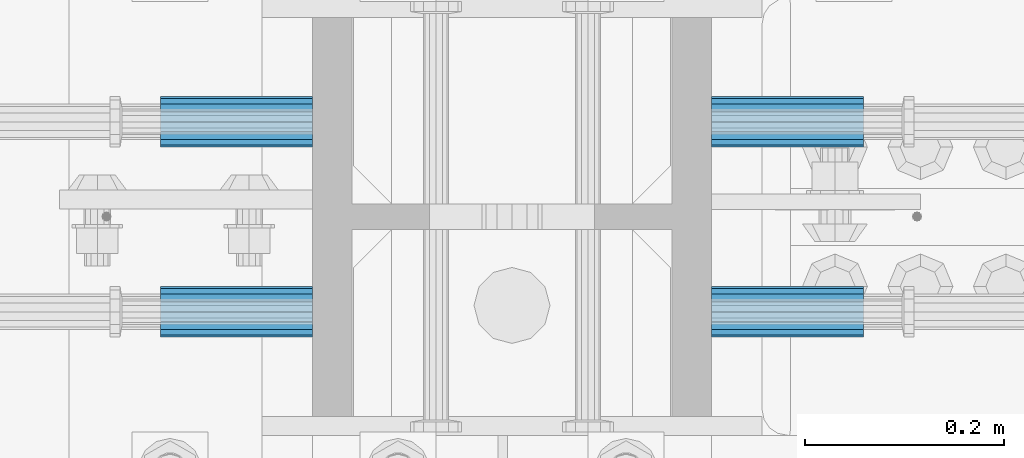
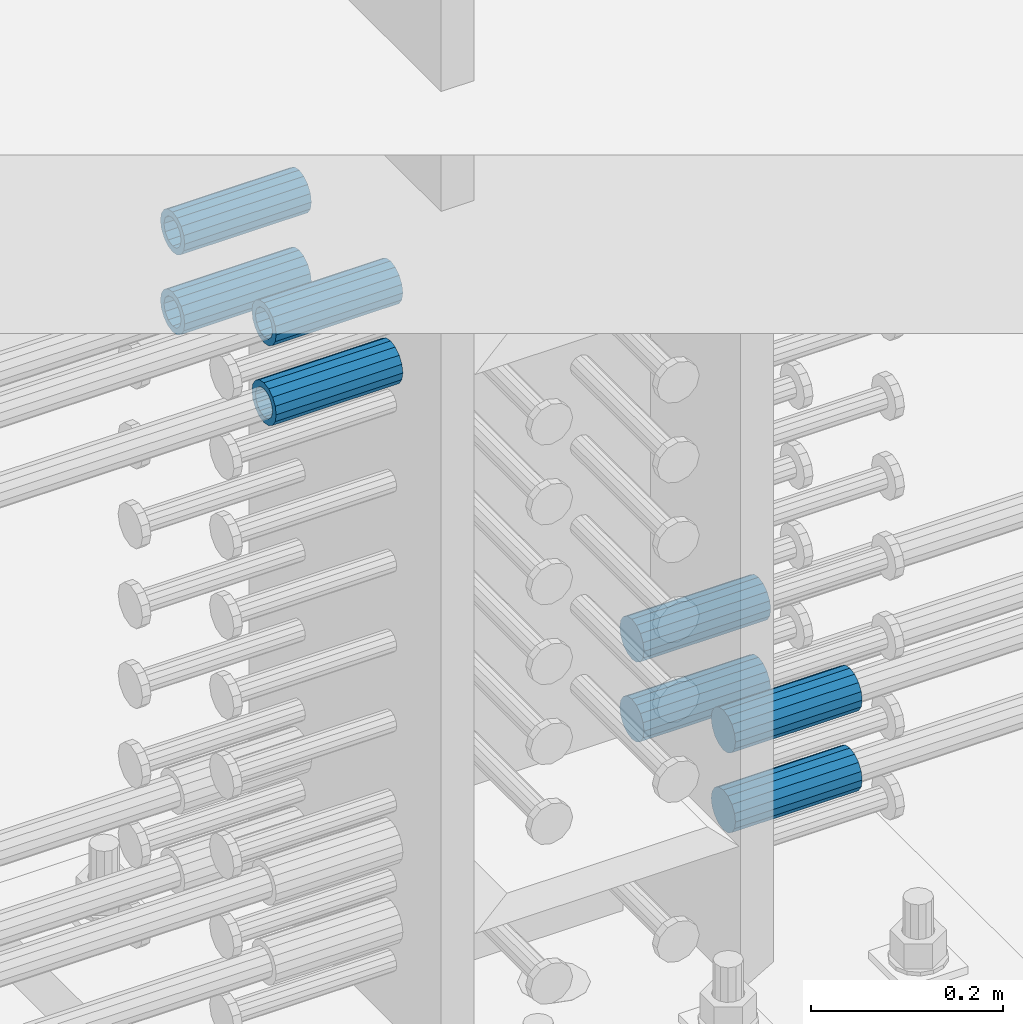
# One storey, part 1187 of 1763: 8 beams, 1 element without a shape of its own.
"""IFC2X3 building model written with IfcOpenShell, lengths in millimetres."""

from ifc_helpers import new_model, si_unit, frame, origin_with_axes, place, context, subcontext, project, spatial, faceted_brep, material, type_object, element, aggregate, save


model = new_model("IFC2X3")

# Units and contexts
model_context = context("Model", 3, precision=1e-05, world=origin_with_axes())
body_context = subcontext(model_context, "Body", "Model", "MODEL_VIEW")
ifc_project = project(units=[si_unit("LENGTHUNIT", "METRE", prefix="MILLI"), si_unit("AREAUNIT", "SQUARE_METRE"), si_unit("VOLUMEUNIT", "CUBIC_METRE"), si_unit("MASSUNIT", "GRAM", prefix="KILO"), si_unit("TIMEUNIT", "SECOND"), si_unit("PLANEANGLEUNIT", "RADIAN"), si_unit("SOLIDANGLEUNIT", "STERADIAN"), si_unit("THERMODYNAMICTEMPERATUREUNIT", "DEGREE_CELSIUS"), si_unit("LUMINOUSINTENSITYUNIT", "LUMEN")], contexts=[model_context])

# Site, building, storey
site_placement = place(None, origin_with_axes())
site = spatial("IfcSite", under=ifc_project, at=site_placement, CompositionType="ELEMENT")
building_placement = place(site_placement, origin_with_axes())
building = spatial("IfcBuilding", under=site, at=building_placement, Name="Undefined", CompositionType="ELEMENT")
storey_placement = place(building_placement, origin_with_axes())
storey = spatial("IfcBuildingStorey", under=building, at=storey_placement, Name="Undefined", CompositionType="ELEMENT", Elevation=0.0)

# Assembly, beams
assembly_placement = place(storey_placement, origin_with_axes())
assembly = element("IfcElementAssembly", 1, at=assembly_placement, inside=storey, Name="COLUMN", AssemblyPlace="NOTDEFINED", PredefinedType="RIGID_FRAME")
ifc_material = material(Name="STEEL/A706-GR.80")
beam_type = type_object("IfcBeamType", PredefinedType="NOTDEFINED")
beam_1_placement = place(assembly_placement, frame((-72691.062342359, 552.450000000255, 4775.20000000008), z_axis=(0.0, 0.0, 1.0), x_axis=(-1.0, 0.0, 0.0)))
beam_1 = element("IfcBeam", 2, at=beam_1_placement, type_object=beam_type, material=ifc_material, Name="HALF COUPLER F", context=body_context, shape_type="Brep", body=[
    faceted_brep([(32.7659999999996, -8.95349999999962, -15.507916905568), (32.7659999999996, 0.0, -17.9070000000002), (32.7659999999996, 8.95349999999962, -15.507916905568), (32.7659999999996, 15.507916905568, -8.95350000000008), (32.7659999999996, 17.9069999999992, 0.0), (32.7659999999996, 15.507916905568, 8.95350000000008), (32.7659999999996, 8.95349999999962, 15.507916905568), (32.7659999999996, 0.0, 17.9070000000002), (32.7659999999996, -8.95349999999962, 15.507916905568), (32.7659999999996, -15.507916905568, 8.95350000000008), (32.7659999999996, -17.9069999999992, 0.0), (32.7659999999996, -15.507916905568, -8.95350000000008), (152.400103102711, -15.507916905568, 8.95350000000008), (152.400103102711, -8.95349999999962, 15.507916905568), (152.400103102711, -17.9069999999992, 0.0), (152.400103102711, -15.507916905568, -8.95350000000008), (152.400103102711, -8.95349999999962, -15.507916905568), (152.400103102711, 0.0, -17.9070000000002), (152.400103102711, 8.95349999999962, -15.507916905568), (152.400103102711, 15.507916905568, -8.95350000000008), (152.400103102711, 17.9069999999992, 0.0), (152.400103102711, 15.507916905568, 8.95350000000008), (152.400103102711, 8.95349999999962, 15.507916905568), (152.400103102711, 0.0, 17.9070000000002), (0.0, -23.466540125788, 9.72015918207308), (0.0, -17.9605122421381, 17.9605122421385), (0.0, -9.72015918207398, 23.4665401257867), (0.0, 0.0, 25.4000000000001), (0.0, 9.72015918207398, 23.4665401257867), (0.0, 17.9605122421381, 17.9605122421385), (0.0, 23.466540125788, 9.72015918207308), (0.0, 25.4000000000015, 0.0), (0.0, 23.466540125788, -9.72015918207308), (0.0, 17.9605122421381, -17.9605122421385), (0.0, 9.72015918207398, -23.4665401257867), (0.0, 0.0, -25.4000000000001), (0.0, -9.72015918207398, -23.4665401257867), (0.0, -17.9605122421381, -17.9605122421385), (0.0, -23.466540125788, -9.72015918207308), (0.0, -25.4000000000015, 0.0), (152.400103102711, -25.4000000000015, 0.0), (152.400103102711, -23.466540125788, 9.72015918207308), (152.400103102711, -17.9605122421381, 17.9605122421385), (152.400103102711, -9.72015918207398, 23.4665401257867), (152.400103102711, 0.0, 25.4000000000001), (152.400103102711, 9.72015918207398, 23.4665401257867), (152.400103102711, 17.9605122421381, 17.9605122421385), (152.400103102711, 23.466540125788, 9.72015918207308), (152.400103102711, 25.4000000000015, 0.0), (152.400103102711, 23.466540125788, -9.72015918207308), (152.400103102711, 17.9605122421381, -17.9605122421385), (152.400103102711, 9.72015918207398, -23.4665401257867), (152.400103102711, 0.0, -25.4000000000001), (152.400103102711, -9.72015918207398, -23.4665401257867), (152.400103102711, -17.9605122421381, -17.9605122421385), (152.400103102711, -23.466540125788, -9.72015918207308)], [[[0, 1, 2, 3, 4, 5, 6, 7, 8, 9, 10, 11]], [[12, 9, 8, 13]], [[14, 10, 9, 12]], [[15, 11, 10, 14]], [[16, 0, 11, 15]], [[17, 1, 0, 16]], [[18, 2, 1, 17]], [[19, 3, 2, 18]], [[20, 4, 3, 19]], [[21, 5, 4, 20]], [[22, 6, 5, 21]], [[23, 7, 6, 22]], [[13, 8, 7, 23]], [[24, 25, 26, 27, 28, 29, 30, 31, 32, 33, 34, 35, 36, 37, 38, 39]], [[24, 39, 40, 41]], [[25, 24, 41, 42]], [[26, 25, 42, 43]], [[27, 26, 43, 44]], [[28, 27, 44, 45]], [[29, 28, 45, 46]], [[30, 29, 46, 47]], [[31, 30, 47, 48]], [[32, 31, 48, 49]], [[33, 32, 49, 50]], [[34, 33, 50, 51]], [[35, 34, 51, 52]], [[36, 35, 52, 53]], [[37, 36, 53, 54]], [[38, 37, 54, 55]], [[39, 38, 55, 40]], [[54, 53, 52, 51, 50, 49, 48, 47, 46, 45, 44, 43, 42, 41, 40, 55], [21, 20, 19, 18, 17, 16, 15, 14, 12, 13, 23, 22]]]),
])
beam_2_placement = place(assembly_placement, frame((-72691.0622736972, 361.950000000843, 4775.20000000008), z_axis=(0.0, 0.0, 1.0), x_axis=(-1.0, 0.0, 0.0)))
beam_2 = element("IfcBeam", 3, at=beam_2_placement, type_object=beam_type, material=ifc_material, Name="HALF COUPLER F", context=body_context, shape_type="Brep", body=[
    faceted_brep([(32.7659999999996, -8.95349999999962, -15.507916905568), (32.7659999999996, 0.0, -17.9070000000002), (32.7659999999996, 8.95349999999962, -15.507916905568), (32.7659999999996, 15.507916905568, -8.95350000000008), (32.7659999999996, 17.9069999999992, 0.0), (32.7659999999996, 15.507916905568, 8.95350000000008), (32.7659999999996, 8.95349999999962, 15.507916905568), (32.7659999999996, 0.0, 17.9070000000002), (32.7659999999996, -8.95349999999962, 15.507916905568), (32.7659999999996, -15.507916905568, 8.95350000000008), (32.7659999999996, -17.9069999999992, 0.0), (32.7659999999996, -15.507916905568, -8.95350000000008), (152.400103102711, -15.507916905568, 8.95350000000008), (152.400103102711, -8.95349999999962, 15.507916905568), (152.400103102711, -17.9069999999992, 0.0), (152.400103102711, -15.507916905568, -8.95350000000008), (152.400103102711, -8.95349999999962, -15.507916905568), (152.400103102711, 0.0, -17.9070000000002), (152.400103102711, 8.95349999999962, -15.507916905568), (152.400103102711, 15.507916905568, -8.95350000000008), (152.400103102711, 17.9069999999992, 0.0), (152.400103102711, 15.507916905568, 8.95350000000008), (152.400103102711, 8.95349999999962, 15.507916905568), (152.400103102711, 0.0, 17.9070000000002), (0.0, -23.466540125788, 9.72015918207308), (0.0, -17.9605122421381, 17.9605122421385), (0.0, -9.72015918207398, 23.4665401257867), (0.0, 0.0, 25.4000000000001), (0.0, 9.72015918207398, 23.4665401257867), (0.0, 17.9605122421381, 17.9605122421385), (0.0, 23.466540125788, 9.72015918207308), (0.0, 25.4000000000015, 0.0), (0.0, 23.466540125788, -9.72015918207308), (0.0, 17.9605122421381, -17.9605122421385), (0.0, 9.72015918207398, -23.4665401257867), (0.0, 0.0, -25.4000000000001), (0.0, -9.72015918207398, -23.4665401257867), (0.0, -17.9605122421381, -17.9605122421385), (0.0, -23.466540125788, -9.72015918207308), (0.0, -25.4000000000015, 0.0), (152.400103102711, -25.4000000000015, 0.0), (152.400103102711, -23.466540125788, 9.72015918207308), (152.400103102711, -17.9605122421381, 17.9605122421385), (152.400103102711, -9.72015918207398, 23.4665401257867), (152.400103102711, 0.0, 25.4000000000001), (152.400103102711, 9.72015918207398, 23.4665401257867), (152.400103102711, 17.9605122421381, 17.9605122421385), (152.400103102711, 23.466540125788, 9.72015918207308), (152.400103102711, 25.4000000000015, 0.0), (152.400103102711, 23.466540125788, -9.72015918207308), (152.400103102711, 17.9605122421381, -17.9605122421385), (152.400103102711, 9.72015918207398, -23.4665401257867), (152.400103102711, 0.0, -25.4000000000001), (152.400103102711, -9.72015918207398, -23.4665401257867), (152.400103102711, -17.9605122421381, -17.9605122421385), (152.400103102711, -23.466540125788, -9.72015918207308)], [[[0, 1, 2, 3, 4, 5, 6, 7, 8, 9, 10, 11]], [[12, 9, 8, 13]], [[14, 10, 9, 12]], [[15, 11, 10, 14]], [[16, 0, 11, 15]], [[17, 1, 0, 16]], [[18, 2, 1, 17]], [[19, 3, 2, 18]], [[20, 4, 3, 19]], [[21, 5, 4, 20]], [[22, 6, 5, 21]], [[23, 7, 6, 22]], [[13, 8, 7, 23]], [[24, 25, 26, 27, 28, 29, 30, 31, 32, 33, 34, 35, 36, 37, 38, 39]], [[24, 39, 40, 41]], [[25, 24, 41, 42]], [[26, 25, 42, 43]], [[27, 26, 43, 44]], [[28, 27, 44, 45]], [[29, 28, 45, 46]], [[30, 29, 46, 47]], [[31, 30, 47, 48]], [[32, 31, 48, 49]], [[33, 32, 49, 50]], [[34, 33, 50, 51]], [[35, 34, 51, 52]], [[36, 35, 52, 53]], [[37, 36, 53, 54]], [[38, 37, 54, 55]], [[39, 38, 55, 40]], [[54, 53, 52, 51, 50, 49, 48, 47, 46, 45, 44, 43, 42, 41, 40, 55], [21, 20, 19, 18, 17, 16, 15, 14, 12, 13, 23, 22]]]),
])
beam_3_placement = place(assembly_placement, frame((-72691.062342359, 552.450000000255, 4876.80000000008), z_axis=(0.0, 0.0, 1.0), x_axis=(-1.0, 0.0, 0.0)))
beam_3 = element("IfcBeam", 4, at=beam_3_placement, type_object=beam_type, material=ifc_material, Name="HALF COUPLER F", context=body_context, shape_type="Brep", body=[
    faceted_brep([(32.7659999999996, -8.95349999999962, -15.507916905568), (32.7659999999996, 0.0, -17.9070000000002), (32.7659999999996, 8.95349999999962, -15.507916905568), (32.7659999999996, 15.507916905568, -8.95350000000008), (32.7659999999996, 17.9069999999992, 0.0), (32.7659999999996, 15.507916905568, 8.95350000000008), (32.7659999999996, 8.95349999999962, 15.507916905568), (32.7659999999996, 0.0, 17.9070000000002), (32.7659999999996, -8.95349999999962, 15.507916905568), (32.7659999999996, -15.507916905568, 8.95350000000008), (32.7659999999996, -17.9069999999992, 0.0), (32.7659999999996, -15.507916905568, -8.95350000000008), (152.400103102711, -15.507916905568, 8.95350000000008), (152.400103102711, -8.95349999999962, 15.507916905568), (152.400103102711, -17.9069999999992, 0.0), (152.400103102711, -15.507916905568, -8.95350000000008), (152.400103102711, -8.95349999999962, -15.507916905568), (152.400103102711, 0.0, -17.9070000000002), (152.400103102711, 8.95349999999962, -15.507916905568), (152.400103102711, 15.507916905568, -8.95350000000008), (152.400103102711, 17.9069999999992, 0.0), (152.400103102711, 15.507916905568, 8.95350000000008), (152.400103102711, 8.95349999999962, 15.507916905568), (152.400103102711, 0.0, 17.9070000000002), (0.0, -23.466540125788, 9.72015918207308), (0.0, -17.9605122421381, 17.9605122421385), (0.0, -9.72015918207398, 23.4665401257867), (0.0, 0.0, 25.4000000000001), (0.0, 9.72015918207398, 23.4665401257867), (0.0, 17.9605122421381, 17.9605122421385), (0.0, 23.466540125788, 9.72015918207308), (0.0, 25.4000000000015, 0.0), (0.0, 23.466540125788, -9.72015918207308), (0.0, 17.9605122421381, -17.9605122421385), (0.0, 9.72015918207398, -23.4665401257867), (0.0, 0.0, -25.4000000000001), (0.0, -9.72015918207398, -23.4665401257867), (0.0, -17.9605122421381, -17.9605122421385), (0.0, -23.466540125788, -9.72015918207308), (0.0, -25.4000000000015, 0.0), (152.400103102711, -25.4000000000015, 0.0), (152.400103102711, -23.466540125788, 9.72015918207308), (152.400103102711, -17.9605122421381, 17.9605122421385), (152.400103102711, -9.72015918207398, 23.4665401257867), (152.400103102711, 0.0, 25.4000000000001), (152.400103102711, 9.72015918207398, 23.4665401257867), (152.400103102711, 17.9605122421381, 17.9605122421385), (152.400103102711, 23.466540125788, 9.72015918207308), (152.400103102711, 25.4000000000015, 0.0), (152.400103102711, 23.466540125788, -9.72015918207308), (152.400103102711, 17.9605122421381, -17.9605122421385), (152.400103102711, 9.72015918207398, -23.4665401257867), (152.400103102711, 0.0, -25.4000000000001), (152.400103102711, -9.72015918207398, -23.4665401257867), (152.400103102711, -17.9605122421381, -17.9605122421385), (152.400103102711, -23.466540125788, -9.72015918207308)], [[[0, 1, 2, 3, 4, 5, 6, 7, 8, 9, 10, 11]], [[12, 9, 8, 13]], [[14, 10, 9, 12]], [[15, 11, 10, 14]], [[16, 0, 11, 15]], [[17, 1, 0, 16]], [[18, 2, 1, 17]], [[19, 3, 2, 18]], [[20, 4, 3, 19]], [[21, 5, 4, 20]], [[22, 6, 5, 21]], [[23, 7, 6, 22]], [[13, 8, 7, 23]], [[24, 25, 26, 27, 28, 29, 30, 31, 32, 33, 34, 35, 36, 37, 38, 39]], [[24, 39, 40, 41]], [[25, 24, 41, 42]], [[26, 25, 42, 43]], [[27, 26, 43, 44]], [[28, 27, 44, 45]], [[29, 28, 45, 46]], [[30, 29, 46, 47]], [[31, 30, 47, 48]], [[32, 31, 48, 49]], [[33, 32, 49, 50]], [[34, 33, 50, 51]], [[35, 34, 51, 52]], [[36, 35, 52, 53]], [[37, 36, 53, 54]], [[38, 37, 54, 55]], [[39, 38, 55, 40]], [[54, 53, 52, 51, 50, 49, 48, 47, 46, 45, 44, 43, 42, 41, 40, 55], [21, 20, 19, 18, 17, 16, 15, 14, 12, 13, 23, 22]]]),
])
beam_4_placement = place(assembly_placement, frame((-72691.0622736972, 361.950000000843, 4876.80000000008), z_axis=(0.0, 0.0, 1.0), x_axis=(-1.0, 0.0, 0.0)))
beam_4 = element("IfcBeam", 5, at=beam_4_placement, type_object=beam_type, material=ifc_material, Name="HALF COUPLER F", context=body_context, shape_type="Brep", body=[
    faceted_brep([(32.7659999999996, -8.95349999999962, -15.507916905568), (32.7659999999996, 0.0, -17.9070000000002), (32.7659999999996, 8.95349999999962, -15.507916905568), (32.7659999999996, 15.507916905568, -8.95350000000008), (32.7659999999996, 17.9069999999992, 0.0), (32.7659999999996, 15.507916905568, 8.95350000000008), (32.7659999999996, 8.95349999999962, 15.507916905568), (32.7659999999996, 0.0, 17.9070000000002), (32.7659999999996, -8.95349999999962, 15.507916905568), (32.7659999999996, -15.507916905568, 8.95350000000008), (32.7659999999996, -17.9069999999992, 0.0), (32.7659999999996, -15.507916905568, -8.95350000000008), (152.400103102711, -15.507916905568, 8.95350000000008), (152.400103102711, -8.95349999999962, 15.507916905568), (152.400103102711, -17.9069999999992, 0.0), (152.400103102711, -15.507916905568, -8.95350000000008), (152.400103102711, -8.95349999999962, -15.507916905568), (152.400103102711, 0.0, -17.9070000000002), (152.400103102711, 8.95349999999962, -15.507916905568), (152.400103102711, 15.507916905568, -8.95350000000008), (152.400103102711, 17.9069999999992, 0.0), (152.400103102711, 15.507916905568, 8.95350000000008), (152.400103102711, 8.95349999999962, 15.507916905568), (152.400103102711, 0.0, 17.9070000000002), (0.0, -23.466540125788, 9.72015918207308), (0.0, -17.9605122421381, 17.9605122421385), (0.0, -9.72015918207398, 23.4665401257867), (0.0, 0.0, 25.4000000000001), (0.0, 9.72015918207398, 23.4665401257867), (0.0, 17.9605122421381, 17.9605122421385), (0.0, 23.466540125788, 9.72015918207308), (0.0, 25.4000000000015, 0.0), (0.0, 23.466540125788, -9.72015918207308), (0.0, 17.9605122421381, -17.9605122421385), (0.0, 9.72015918207398, -23.4665401257867), (0.0, 0.0, -25.4000000000001), (0.0, -9.72015918207398, -23.4665401257867), (0.0, -17.9605122421381, -17.9605122421385), (0.0, -23.466540125788, -9.72015918207308), (0.0, -25.4000000000015, 0.0), (152.400103102711, -25.4000000000015, 0.0), (152.400103102711, -23.466540125788, 9.72015918207308), (152.400103102711, -17.9605122421381, 17.9605122421385), (152.400103102711, -9.72015918207398, 23.4665401257867), (152.400103102711, 0.0, 25.4000000000001), (152.400103102711, 9.72015918207398, 23.4665401257867), (152.400103102711, 17.9605122421381, 17.9605122421385), (152.400103102711, 23.466540125788, 9.72015918207308), (152.400103102711, 25.4000000000015, 0.0), (152.400103102711, 23.466540125788, -9.72015918207308), (152.400103102711, 17.9605122421381, -17.9605122421385), (152.400103102711, 9.72015918207398, -23.4665401257867), (152.400103102711, 0.0, -25.4000000000001), (152.400103102711, -9.72015918207398, -23.4665401257867), (152.400103102711, -17.9605122421381, -17.9605122421385), (152.400103102711, -23.466540125788, -9.72015918207308)], [[[0, 1, 2, 3, 4, 5, 6, 7, 8, 9, 10, 11]], [[12, 9, 8, 13]], [[14, 10, 9, 12]], [[15, 11, 10, 14]], [[16, 0, 11, 15]], [[17, 1, 0, 16]], [[18, 2, 1, 17]], [[19, 3, 2, 18]], [[20, 4, 3, 19]], [[21, 5, 4, 20]], [[22, 6, 5, 21]], [[23, 7, 6, 22]], [[13, 8, 7, 23]], [[24, 25, 26, 27, 28, 29, 30, 31, 32, 33, 34, 35, 36, 37, 38, 39]], [[24, 39, 40, 41]], [[25, 24, 41, 42]], [[26, 25, 42, 43]], [[27, 26, 43, 44]], [[28, 27, 44, 45]], [[29, 28, 45, 46]], [[30, 29, 46, 47]], [[31, 30, 47, 48]], [[32, 31, 48, 49]], [[33, 32, 49, 50]], [[34, 33, 50, 51]], [[35, 34, 51, 52]], [[36, 35, 52, 53]], [[37, 36, 53, 54]], [[38, 37, 54, 55]], [[39, 38, 55, 40]], [[54, 53, 52, 51, 50, 49, 48, 47, 46, 45, 44, 43, 42, 41, 40, 55], [21, 20, 19, 18, 17, 16, 15, 14, 12, 13, 23, 22]]]),
])
beam_5_placement = place(assembly_placement, frame((-72291.0122049617, 552.450000000255, 4063.99999999999), z_axis=(0.0, 0.0, 1.0), x_axis=(1.0, 0.0, 0.0)))
beam_5 = element("IfcBeam", 6, at=beam_5_placement, type_object=beam_type, material=ifc_material, Name="HALF COUPLER F", context=body_context, shape_type="Brep", body=[
    faceted_brep([(32.7659999999996, -8.95349999999962, -15.507916905568), (32.7659999999996, 0.0, -17.9070000000002), (32.7659999999996, 8.95349999999962, -15.507916905568), (32.7659999999996, 15.507916905568, -8.95350000000008), (32.7659999999996, 17.9069999999992, 0.0), (32.7659999999996, 15.507916905568, 8.95350000000008), (32.7659999999996, 8.95349999999962, 15.507916905568), (32.7659999999996, 0.0, 17.9070000000002), (32.7659999999996, -8.95349999999962, 15.507916905568), (32.7659999999996, -15.507916905568, 8.95350000000008), (32.7659999999996, -17.9069999999992, 0.0), (32.7659999999996, -15.507916905568, -8.95350000000008), (152.400103102711, -15.507916905568, 8.95350000000008), (152.400103102711, -8.95349999999962, 15.507916905568), (152.400103102711, -17.9069999999992, 0.0), (152.400103102711, -15.507916905568, -8.95350000000008), (152.400103102711, -8.95349999999962, -15.507916905568), (152.400103102711, 0.0, -17.9070000000002), (152.400103102711, 8.95349999999962, -15.507916905568), (152.400103102711, 15.507916905568, -8.95350000000008), (152.400103102711, 17.9069999999992, 0.0), (152.400103102711, 15.507916905568, 8.95350000000008), (152.400103102711, 8.95349999999962, 15.507916905568), (152.400103102711, 0.0, 17.9070000000002), (0.0, -23.466540125788, 9.72015918207308), (0.0, -17.9605122421381, 17.9605122421385), (0.0, -9.72015918207398, 23.4665401257867), (0.0, 0.0, 25.4000000000001), (0.0, 9.72015918207398, 23.4665401257867), (0.0, 17.9605122421381, 17.9605122421385), (0.0, 23.466540125788, 9.72015918207308), (0.0, 25.4000000000015, 0.0), (0.0, 23.466540125788, -9.72015918207308), (0.0, 17.9605122421381, -17.9605122421385), (0.0, 9.72015918207398, -23.4665401257867), (0.0, 0.0, -25.4000000000001), (0.0, -9.72015918207398, -23.4665401257867), (0.0, -17.9605122421381, -17.9605122421385), (0.0, -23.466540125788, -9.72015918207308), (0.0, -25.4000000000015, 0.0), (152.400103102711, -25.4000000000015, 0.0), (152.400103102711, -23.466540125788, 9.72015918207308), (152.400103102711, -17.9605122421381, 17.9605122421385), (152.400103102711, -9.72015918207398, 23.4665401257867), (152.400103102711, 0.0, 25.4000000000001), (152.400103102711, 9.72015918207398, 23.4665401257867), (152.400103102711, 17.9605122421381, 17.9605122421385), (152.400103102711, 23.466540125788, 9.72015918207308), (152.400103102711, 25.4000000000015, 0.0), (152.400103102711, 23.466540125788, -9.72015918207308), (152.400103102711, 17.9605122421381, -17.9605122421385), (152.400103102711, 9.72015918207398, -23.4665401257867), (152.400103102711, 0.0, -25.4000000000001), (152.400103102711, -9.72015918207398, -23.4665401257867), (152.400103102711, -17.9605122421381, -17.9605122421385), (152.400103102711, -23.466540125788, -9.72015918207308)], [[[0, 1, 2, 3, 4, 5, 6, 7, 8, 9, 10, 11]], [[12, 9, 8, 13]], [[14, 10, 9, 12]], [[15, 11, 10, 14]], [[16, 0, 11, 15]], [[17, 1, 0, 16]], [[18, 2, 1, 17]], [[19, 3, 2, 18]], [[20, 4, 3, 19]], [[21, 5, 4, 20]], [[22, 6, 5, 21]], [[23, 7, 6, 22]], [[13, 8, 7, 23]], [[24, 25, 26, 27, 28, 29, 30, 31, 32, 33, 34, 35, 36, 37, 38, 39]], [[24, 39, 40, 41]], [[25, 24, 41, 42]], [[26, 25, 42, 43]], [[27, 26, 43, 44]], [[28, 27, 44, 45]], [[29, 28, 45, 46]], [[30, 29, 46, 47]], [[31, 30, 47, 48]], [[32, 31, 48, 49]], [[33, 32, 49, 50]], [[34, 33, 50, 51]], [[35, 34, 51, 52]], [[36, 35, 52, 53]], [[37, 36, 53, 54]], [[38, 37, 54, 55]], [[39, 38, 55, 40]], [[54, 53, 52, 51, 50, 49, 48, 47, 46, 45, 44, 43, 42, 41, 40, 55], [21, 20, 19, 18, 17, 16, 15, 14, 12, 13, 23, 22]]]),
])
beam_6_placement = place(assembly_placement, frame((-72291.0122736235, 361.950000000843, 4063.99999999999), z_axis=(0.0, 0.0, 1.0), x_axis=(1.0, 0.0, 0.0)))
beam_6 = element("IfcBeam", 7, at=beam_6_placement, type_object=beam_type, material=ifc_material, Name="HALF COUPLER F", context=body_context, shape_type="Brep", body=[
    faceted_brep([(32.7659999999996, -8.95349999999962, -15.507916905568), (32.7659999999996, 0.0, -17.9070000000002), (32.7659999999996, 8.95349999999962, -15.507916905568), (32.7659999999996, 15.507916905568, -8.95350000000008), (32.7659999999996, 17.9069999999992, 0.0), (32.7659999999996, 15.507916905568, 8.95350000000008), (32.7659999999996, 8.95349999999962, 15.507916905568), (32.7659999999996, 0.0, 17.9070000000002), (32.7659999999996, -8.95349999999962, 15.507916905568), (32.7659999999996, -15.507916905568, 8.95350000000008), (32.7659999999996, -17.9069999999992, 0.0), (32.7659999999996, -15.507916905568, -8.95350000000008), (152.400103102711, -15.507916905568, 8.95350000000008), (152.400103102711, -8.95349999999962, 15.507916905568), (152.400103102711, -17.9069999999992, 0.0), (152.400103102711, -15.507916905568, -8.95350000000008), (152.400103102711, -8.95349999999962, -15.507916905568), (152.400103102711, 0.0, -17.9070000000002), (152.400103102711, 8.95349999999962, -15.507916905568), (152.400103102711, 15.507916905568, -8.95350000000008), (152.400103102711, 17.9069999999992, 0.0), (152.400103102711, 15.507916905568, 8.95350000000008), (152.400103102711, 8.95349999999962, 15.507916905568), (152.400103102711, 0.0, 17.9070000000002), (0.0, -23.466540125788, 9.72015918207308), (0.0, -17.9605122421381, 17.9605122421385), (0.0, -9.72015918207398, 23.4665401257867), (0.0, 0.0, 25.4000000000001), (0.0, 9.72015918207398, 23.4665401257867), (0.0, 17.9605122421381, 17.9605122421385), (0.0, 23.466540125788, 9.72015918207308), (0.0, 25.4000000000015, 0.0), (0.0, 23.466540125788, -9.72015918207308), (0.0, 17.9605122421381, -17.9605122421385), (0.0, 9.72015918207398, -23.4665401257867), (0.0, 0.0, -25.4000000000001), (0.0, -9.72015918207398, -23.4665401257867), (0.0, -17.9605122421381, -17.9605122421385), (0.0, -23.466540125788, -9.72015918207308), (0.0, -25.4000000000015, 0.0), (152.400103102711, -25.4000000000015, 0.0), (152.400103102711, -23.466540125788, 9.72015918207308), (152.400103102711, -17.9605122421381, 17.9605122421385), (152.400103102711, -9.72015918207398, 23.4665401257867), (152.400103102711, 0.0, 25.4000000000001), (152.400103102711, 9.72015918207398, 23.4665401257867), (152.400103102711, 17.9605122421381, 17.9605122421385), (152.400103102711, 23.466540125788, 9.72015918207308), (152.400103102711, 25.4000000000015, 0.0), (152.400103102711, 23.466540125788, -9.72015918207308), (152.400103102711, 17.9605122421381, -17.9605122421385), (152.400103102711, 9.72015918207398, -23.4665401257867), (152.400103102711, 0.0, -25.4000000000001), (152.400103102711, -9.72015918207398, -23.4665401257867), (152.400103102711, -17.9605122421381, -17.9605122421385), (152.400103102711, -23.466540125788, -9.72015918207308)], [[[0, 1, 2, 3, 4, 5, 6, 7, 8, 9, 10, 11]], [[12, 9, 8, 13]], [[14, 10, 9, 12]], [[15, 11, 10, 14]], [[16, 0, 11, 15]], [[17, 1, 0, 16]], [[18, 2, 1, 17]], [[19, 3, 2, 18]], [[20, 4, 3, 19]], [[21, 5, 4, 20]], [[22, 6, 5, 21]], [[23, 7, 6, 22]], [[13, 8, 7, 23]], [[24, 25, 26, 27, 28, 29, 30, 31, 32, 33, 34, 35, 36, 37, 38, 39]], [[24, 39, 40, 41]], [[25, 24, 41, 42]], [[26, 25, 42, 43]], [[27, 26, 43, 44]], [[28, 27, 44, 45]], [[29, 28, 45, 46]], [[30, 29, 46, 47]], [[31, 30, 47, 48]], [[32, 31, 48, 49]], [[33, 32, 49, 50]], [[34, 33, 50, 51]], [[35, 34, 51, 52]], [[36, 35, 52, 53]], [[37, 36, 53, 54]], [[38, 37, 54, 55]], [[39, 38, 55, 40]], [[54, 53, 52, 51, 50, 49, 48, 47, 46, 45, 44, 43, 42, 41, 40, 55], [21, 20, 19, 18, 17, 16, 15, 14, 12, 13, 23, 22]]]),
])
beam_7_placement = place(assembly_placement, frame((-72291.0122049617, 552.450000000255, 4165.60000000002), z_axis=(0.0, 0.0, 1.0), x_axis=(1.0, 0.0, 0.0)))
beam_7 = element("IfcBeam", 8, at=beam_7_placement, type_object=beam_type, material=ifc_material, Name="HALF COUPLER F", context=body_context, shape_type="Brep", body=[
    faceted_brep([(32.7659999999996, -8.95349999999962, -15.507916905568), (32.7659999999996, 0.0, -17.9070000000002), (32.7659999999996, 8.95349999999962, -15.507916905568), (32.7659999999996, 15.507916905568, -8.95350000000008), (32.7659999999996, 17.9069999999992, 0.0), (32.7659999999996, 15.507916905568, 8.95350000000008), (32.7659999999996, 8.95349999999962, 15.507916905568), (32.7659999999996, 0.0, 17.9070000000002), (32.7659999999996, -8.95349999999962, 15.507916905568), (32.7659999999996, -15.507916905568, 8.95350000000008), (32.7659999999996, -17.9069999999992, 0.0), (32.7659999999996, -15.507916905568, -8.95350000000008), (152.400103102711, -15.507916905568, 8.95350000000008), (152.400103102711, -8.95349999999962, 15.507916905568), (152.400103102711, -17.9069999999992, 0.0), (152.400103102711, -15.507916905568, -8.95350000000008), (152.400103102711, -8.95349999999962, -15.507916905568), (152.400103102711, 0.0, -17.9070000000002), (152.400103102711, 8.95349999999962, -15.507916905568), (152.400103102711, 15.507916905568, -8.95350000000008), (152.400103102711, 17.9069999999992, 0.0), (152.400103102711, 15.507916905568, 8.95350000000008), (152.400103102711, 8.95349999999962, 15.507916905568), (152.400103102711, 0.0, 17.9070000000002), (0.0, -23.466540125788, 9.72015918207308), (0.0, -17.9605122421381, 17.9605122421385), (0.0, -9.72015918207398, 23.4665401257867), (0.0, 0.0, 25.4000000000001), (0.0, 9.72015918207398, 23.4665401257867), (0.0, 17.9605122421381, 17.9605122421385), (0.0, 23.466540125788, 9.72015918207308), (0.0, 25.4000000000015, 0.0), (0.0, 23.466540125788, -9.72015918207308), (0.0, 17.9605122421381, -17.9605122421385), (0.0, 9.72015918207398, -23.4665401257867), (0.0, 0.0, -25.4000000000001), (0.0, -9.72015918207398, -23.4665401257867), (0.0, -17.9605122421381, -17.9605122421385), (0.0, -23.466540125788, -9.72015918207308), (0.0, -25.4000000000015, 0.0), (152.400103102711, -25.4000000000015, 0.0), (152.400103102711, -23.466540125788, 9.72015918207308), (152.400103102711, -17.9605122421381, 17.9605122421385), (152.400103102711, -9.72015918207398, 23.4665401257867), (152.400103102711, 0.0, 25.4000000000001), (152.400103102711, 9.72015918207398, 23.4665401257867), (152.400103102711, 17.9605122421381, 17.9605122421385), (152.400103102711, 23.466540125788, 9.72015918207308), (152.400103102711, 25.4000000000015, 0.0), (152.400103102711, 23.466540125788, -9.72015918207308), (152.400103102711, 17.9605122421381, -17.9605122421385), (152.400103102711, 9.72015918207398, -23.4665401257867), (152.400103102711, 0.0, -25.4000000000001), (152.400103102711, -9.72015918207398, -23.4665401257867), (152.400103102711, -17.9605122421381, -17.9605122421385), (152.400103102711, -23.466540125788, -9.72015918207308)], [[[0, 1, 2, 3, 4, 5, 6, 7, 8, 9, 10, 11]], [[12, 9, 8, 13]], [[14, 10, 9, 12]], [[15, 11, 10, 14]], [[16, 0, 11, 15]], [[17, 1, 0, 16]], [[18, 2, 1, 17]], [[19, 3, 2, 18]], [[20, 4, 3, 19]], [[21, 5, 4, 20]], [[22, 6, 5, 21]], [[23, 7, 6, 22]], [[13, 8, 7, 23]], [[24, 25, 26, 27, 28, 29, 30, 31, 32, 33, 34, 35, 36, 37, 38, 39]], [[24, 39, 40, 41]], [[25, 24, 41, 42]], [[26, 25, 42, 43]], [[27, 26, 43, 44]], [[28, 27, 44, 45]], [[29, 28, 45, 46]], [[30, 29, 46, 47]], [[31, 30, 47, 48]], [[32, 31, 48, 49]], [[33, 32, 49, 50]], [[34, 33, 50, 51]], [[35, 34, 51, 52]], [[36, 35, 52, 53]], [[37, 36, 53, 54]], [[38, 37, 54, 55]], [[39, 38, 55, 40]], [[54, 53, 52, 51, 50, 49, 48, 47, 46, 45, 44, 43, 42, 41, 40, 55], [21, 20, 19, 18, 17, 16, 15, 14, 12, 13, 23, 22]]]),
])
beam_8_placement = place(assembly_placement, frame((-72291.0122736235, 361.950000000843, 4165.60000000002), z_axis=(0.0, 0.0, 1.0), x_axis=(1.0, 0.0, 0.0)))
beam_8 = element("IfcBeam", 9, at=beam_8_placement, type_object=beam_type, material=ifc_material, Name="HALF COUPLER F", context=body_context, shape_type="Brep", body=[
    faceted_brep([(32.7659999999996, -8.95349999999962, -15.507916905568), (32.7659999999996, 0.0, -17.9070000000002), (32.7659999999996, 8.95349999999962, -15.507916905568), (32.7659999999996, 15.507916905568, -8.95350000000008), (32.7659999999996, 17.9069999999992, 0.0), (32.7659999999996, 15.507916905568, 8.95350000000008), (32.7659999999996, 8.95349999999962, 15.507916905568), (32.7659999999996, 0.0, 17.9070000000002), (32.7659999999996, -8.95349999999962, 15.507916905568), (32.7659999999996, -15.507916905568, 8.95350000000008), (32.7659999999996, -17.9069999999992, 0.0), (32.7659999999996, -15.507916905568, -8.95350000000008), (152.400103102711, -15.507916905568, 8.95350000000008), (152.400103102711, -8.95349999999962, 15.507916905568), (152.400103102711, -17.9069999999992, 0.0), (152.400103102711, -15.507916905568, -8.95350000000008), (152.400103102711, -8.95349999999962, -15.507916905568), (152.400103102711, 0.0, -17.9070000000002), (152.400103102711, 8.95349999999962, -15.507916905568), (152.400103102711, 15.507916905568, -8.95350000000008), (152.400103102711, 17.9069999999992, 0.0), (152.400103102711, 15.507916905568, 8.95350000000008), (152.400103102711, 8.95349999999962, 15.507916905568), (152.400103102711, 0.0, 17.9070000000002), (0.0, -23.466540125788, 9.72015918207308), (0.0, -17.9605122421381, 17.9605122421385), (0.0, -9.72015918207398, 23.4665401257867), (0.0, 0.0, 25.4000000000001), (0.0, 9.72015918207398, 23.4665401257867), (0.0, 17.9605122421381, 17.9605122421385), (0.0, 23.466540125788, 9.72015918207308), (0.0, 25.4000000000015, 0.0), (0.0, 23.466540125788, -9.72015918207308), (0.0, 17.9605122421381, -17.9605122421385), (0.0, 9.72015918207398, -23.4665401257867), (0.0, 0.0, -25.4000000000001), (0.0, -9.72015918207398, -23.4665401257867), (0.0, -17.9605122421381, -17.9605122421385), (0.0, -23.466540125788, -9.72015918207308), (0.0, -25.4000000000015, 0.0), (152.400103102711, -25.4000000000015, 0.0), (152.400103102711, -23.466540125788, 9.72015918207308), (152.400103102711, -17.9605122421381, 17.9605122421385), (152.400103102711, -9.72015918207398, 23.4665401257867), (152.400103102711, 0.0, 25.4000000000001), (152.400103102711, 9.72015918207398, 23.4665401257867), (152.400103102711, 17.9605122421381, 17.9605122421385), (152.400103102711, 23.466540125788, 9.72015918207308), (152.400103102711, 25.4000000000015, 0.0), (152.400103102711, 23.466540125788, -9.72015918207308), (152.400103102711, 17.9605122421381, -17.9605122421385), (152.400103102711, 9.72015918207398, -23.4665401257867), (152.400103102711, 0.0, -25.4000000000001), (152.400103102711, -9.72015918207398, -23.4665401257867), (152.400103102711, -17.9605122421381, -17.9605122421385), (152.400103102711, -23.466540125788, -9.72015918207308)], [[[0, 1, 2, 3, 4, 5, 6, 7, 8, 9, 10, 11]], [[12, 9, 8, 13]], [[14, 10, 9, 12]], [[15, 11, 10, 14]], [[16, 0, 11, 15]], [[17, 1, 0, 16]], [[18, 2, 1, 17]], [[19, 3, 2, 18]], [[20, 4, 3, 19]], [[21, 5, 4, 20]], [[22, 6, 5, 21]], [[23, 7, 6, 22]], [[13, 8, 7, 23]], [[24, 25, 26, 27, 28, 29, 30, 31, 32, 33, 34, 35, 36, 37, 38, 39]], [[24, 39, 40, 41]], [[25, 24, 41, 42]], [[26, 25, 42, 43]], [[27, 26, 43, 44]], [[28, 27, 44, 45]], [[29, 28, 45, 46]], [[30, 29, 46, 47]], [[31, 30, 47, 48]], [[32, 31, 48, 49]], [[33, 32, 49, 50]], [[34, 33, 50, 51]], [[35, 34, 51, 52]], [[36, 35, 52, 53]], [[37, 36, 53, 54]], [[38, 37, 54, 55]], [[39, 38, 55, 40]], [[54, 53, 52, 51, 50, 49, 48, 47, 46, 45, 44, 43, 42, 41, 40, 55], [21, 20, 19, 18, 17, 16, 15, 14, 12, 13, 23, 22]]]),
])
aggregate(assembly, [beam_1, beam_2, beam_3, beam_4, beam_5, beam_6, beam_7, beam_8])

save(model, "model.ifc")
